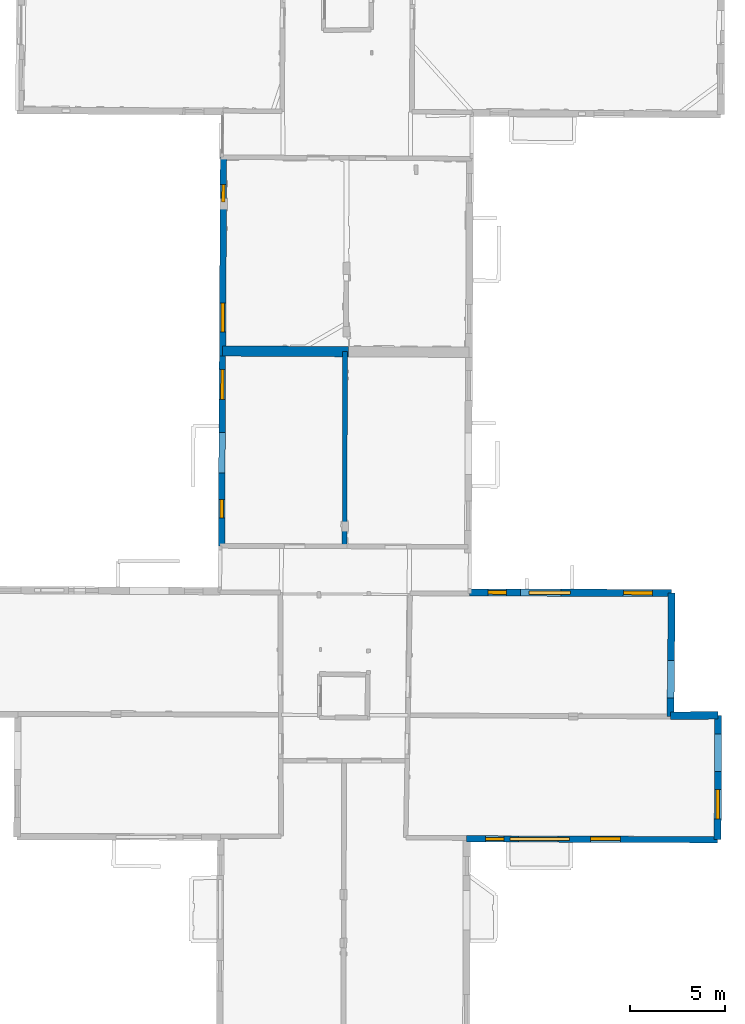
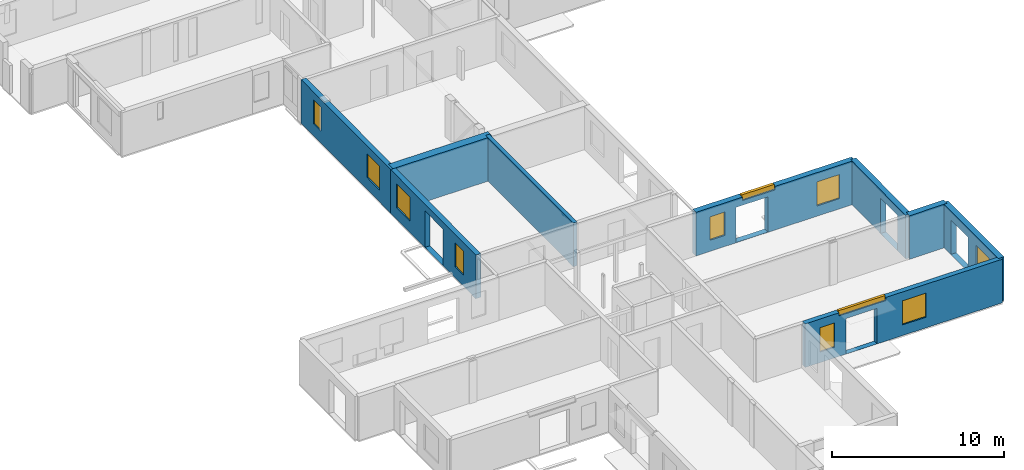
# One storey, part 7 of 17: 11 windows, 9 walls, 16 openings.
"""IFC2X3 building model written with IfcOpenShell, lengths in metres."""

from ifc_helpers import new_model, entity, si_unit, converted_unit, derived_unit, direction, frame, frame_2d, origin, origin_2d_with_axis, place, context, subcontext, project, spatial, polyline, rectangle, outline, extrude, clip, halfspace, source, transform, mapped, material, layer, layer_set, layer_usage, type_object, type_shapes, element, fill, save


model = new_model("IFC2X3")

# Units and contexts
model_context = context("Model", 3, precision=1e-05, world=origin(), true_north=direction((0.0, 1.0)))
body_context = subcontext(model_context, "Body", "Model", "MODEL_VIEW")
ifc_project = project(units=[si_unit("LENGTHUNIT", "METRE"), si_unit("AREAUNIT", "SQUARE_METRE"), si_unit("VOLUMEUNIT", "CUBIC_METRE"), converted_unit("PLANEANGLEUNIT", "DEGREE", entity("IfcRatioMeasure", 0.0174532925199433), si_unit("PLANEANGLEUNIT", "RADIAN"), dimensions=[0, 0, 0, 0, 0, 0, 0]), si_unit("MASSUNIT", "GRAM", prefix="KILO"), derived_unit("MASSDENSITYUNIT", [(si_unit("MASSUNIT", "GRAM", prefix="KILO"), 1), (si_unit("LENGTHUNIT", "METRE"), -3)]), derived_unit("MOMENTOFINERTIAUNIT", [(si_unit("LENGTHUNIT", "METRE"), 4)]), si_unit("TIMEUNIT", "SECOND"), si_unit("FREQUENCYUNIT", "HERTZ"), si_unit("THERMODYNAMICTEMPERATUREUNIT", "DEGREE_CELSIUS"), derived_unit("THERMALTRANSMITTANCEUNIT", [(si_unit("MASSUNIT", "GRAM", prefix="KILO"), 1), (si_unit("THERMODYNAMICTEMPERATUREUNIT", "KELVIN"), -1), (si_unit("TIMEUNIT", "SECOND"), -3)]), derived_unit("VOLUMETRICFLOWRATEUNIT", [(si_unit("LENGTHUNIT", "METRE"), 3), (si_unit("TIMEUNIT", "SECOND"), -1)]), si_unit("ELECTRICCURRENTUNIT", "AMPERE"), si_unit("ELECTRICVOLTAGEUNIT", "VOLT"), si_unit("POWERUNIT", "WATT"), si_unit("FORCEUNIT", "NEWTON", prefix="KILO"), si_unit("ILLUMINANCEUNIT", "LUX"), si_unit("LUMINOUSFLUXUNIT", "LUMEN"), si_unit("LUMINOUSINTENSITYUNIT", "CANDELA"), derived_unit("USERDEFINED", [(si_unit("MASSUNIT", "GRAM", prefix="KILO"), -1), (si_unit("LENGTHUNIT", "METRE"), -2), (si_unit("TIMEUNIT", "SECOND"), 3), (si_unit("LUMINOUSFLUXUNIT", "LUMEN"), 1)]), derived_unit("LINEARVELOCITYUNIT", [(si_unit("LENGTHUNIT", "METRE"), 1), (si_unit("TIMEUNIT", "SECOND"), -1)]), si_unit("PRESSUREUNIT", "PASCAL"), derived_unit("USERDEFINED", [(si_unit("LENGTHUNIT", "METRE"), -2), (si_unit("MASSUNIT", "GRAM", prefix="KILO"), 1), (si_unit("TIMEUNIT", "SECOND"), -2)]), derived_unit("LINEARFORCEUNIT", [(si_unit("MASSUNIT", "GRAM", prefix="KILO"), 1), (si_unit("LENGTHUNIT", "METRE"), 1), (si_unit("TIMEUNIT", "SECOND"), -2), (si_unit("LENGTHUNIT", "METRE"), -1)]), derived_unit("PLANARFORCEUNIT", [(si_unit("MASSUNIT", "GRAM", prefix="KILO"), 1), (si_unit("LENGTHUNIT", "METRE"), 1), (si_unit("TIMEUNIT", "SECOND"), -2), (si_unit("LENGTHUNIT", "METRE"), -2)])], contexts=[model_context])

# Site, building, storey
placement = place(None, origin())
site = spatial("IfcSite", under=ifc_project, at=placement, CompositionType="ELEMENT")
building = spatial("IfcBuilding", under=site, at=placement, CompositionType="ELEMENT")
storey_placement = place(placement, frame((0.0, 0.0, 12.0782108306885)))
storey = spatial("IfcBuildingStorey", under=building, at=storey_placement, Name="Level 5", CompositionType="ELEMENT", Elevation=12.0782108306885)

# Wall
ifc_material_1 = material(Name="Default wall")
ifc_layer_1 = layer(ifc_material_1, 0.25)
ifc_layer_set_1 = layer_set([ifc_layer_1], Name="wall_thickness_0.2500")
ifc_layer_usage_1 = layer_usage(ifc_layer_set_1, "AXIS2", "POSITIVE", -0.125)
wall_type_1 = type_object("IfcWallType", Name="wall_thickness_0.2500", PredefinedType="STANDARD", material=ifc_layer_set_1)
wall_1_placement = place(storey_placement, frame((6.2425833190648, 38.5537895721805, 0.0), z_axis=(0.0, 0.0, 1.0), x_axis=(-0.00288737001704187, -0.999995831538504, 0.0)))
element("IfcWallStandardCase", 1, at=wall_1_placement, inside=storey, type_object=wall_type_1, material=ifc_layer_usage_1, Name="Wall:287", ObjectType="Wall", context=body_context, shape_type="Clipping", body=[
    clip(extrude(outline(polyline([(10.2515934078109, -0.125), (10.2515934078109, 0.125), (0.0, 0.125), (0.0, -0.125), (10.2515934078109, -0.125)])), origin(), (0.0, 0.0, 1.0), 3.09134044647217), halfspace(frame((-37.2681875704859, -7.61302291375945, 5.79573318480268), z_axis=(-0.000288643336191914, -0.389900666933397, 0.920856876289642), x_axis=(0.00288817110946058, 0.920851484728657, 0.389902810378011)), False)),
])

# Wall, openings, windows
ifc_layer_2 = layer(ifc_material_1, 0.330000013113022)
ifc_layer_set_2 = layer_set([ifc_layer_2], Name="wall_thickness_0.3300")
ifc_layer_usage_2 = layer_usage(ifc_layer_set_2, "AXIS2", "POSITIVE", -0.165000006556511)
wall_type_2 = type_object("IfcWallType", Name="wall_thickness_0.3300", PredefinedType="STANDARD", material=ifc_layer_set_2)
wall_2_placement = place(storey_placement, frame((12.6459443218258, 12.9034908118024, 0.0), z_axis=(0.0, 0.0, 1.0), x_axis=(0.999992685574327, -0.00382476114882591, 0.0)))
wall_2 = element("IfcWallStandardCase", 2, at=wall_2_placement, inside=storey, type_object=wall_type_2, material=ifc_layer_usage_2, Name="Wall:361", ObjectType="Wall", context=body_context, shape_type="Clipping", body=[
    clip(extrude(outline(polyline([(13.21563468968, -0.165000006556511), (13.21563468968, 0.165000006556511), (0.0, 0.165000006556511), (0.0, -0.165000006556511), (13.21563468968, -0.165000006556511)])), origin(), (0.0, 0.0, 1.0), 3.09134044647217), halfspace(frame((-24.7044513587916, 6.59599809914678, 8.98689858314154), z_axis=(-0.00280531431875149, -0.389131394824783, 0.921177989192801), x_axis=(0.999981974712468, -0.0059817594498919, 0.000518463148508191)), False)),
])
opening_1_placement = place(wall_2_placement, frame((2.7329397110694, -0.165000006556511, 0.00578975677490234)))
element("IfcOpeningElement", 3, at=opening_1_placement, cuts=wall_2, Name="Opening : 2080 x 2520 : 295", ObjectType="Opening", context=body_context, shape_type="SweptSolid", body=[
    extrude(rectangle(XDim=2.08, YDim=2.52, at=frame_2d((1.26, 1.04), x_axis=(0.0, 1.0))), frame((0.0, 0.0, 0.0), z_axis=(0.0, 1.0, 0.0), x_axis=(0.0, 0.0, 1.0)), (0.0, 0.0, 1.0), 0.330000013113022),
])
opening_2_placement = place(wall_2_placement, frame((2.2772059384736, -0.165000006556511, 2.87078952789307)))
opening_2 = element("IfcOpeningElement", 4, at=opening_2_placement, cuts=wall_2, Name="Opening : 3125 x 310 : 296", ObjectType="Opening", context=body_context, shape_type="SweptSolid", body=[
    extrude(rectangle(XDim=3.125, YDim=0.31, at=frame_2d((0.155, 1.5625), x_axis=(0.0, 1.0))), frame((0.0, 0.0, 0.0), z_axis=(0.0, 1.0, 0.0), x_axis=(0.0, 0.0, 1.0)), (0.0, 0.0, 1.0), 0.330000013113022),
])
opening_3_placement = place(wall_2_placement, frame((6.52720650410301, -0.165000006556511, 0.755789756774902)))
opening_3 = element("IfcOpeningElement", 5, at=opening_3_placement, cuts=wall_2, Name="Opening : 1565 x 1710 : 297", ObjectType="Opening", context=body_context, shape_type="SweptSolid", body=[
    extrude(rectangle(XDim=1.565, YDim=1.71, at=frame_2d((0.855, 0.7825), x_axis=(0.0, 1.0))), frame((0.0, 0.0, 0.0), z_axis=(0.0, 1.0, 0.0), x_axis=(0.0, 0.0, 1.0)), (0.0, 0.0, 1.0), 0.330000013113022),
])
opening_4_placement = place(wall_2_placement, frame((0.987207030009488, -0.165000006556511, 0.755789756774902)))
opening_4 = element("IfcOpeningElement", 6, at=opening_4_placement, cuts=wall_2, Name="Opening : 980 x 1725 : 298", ObjectType="Opening", context=body_context, shape_type="SweptSolid", body=[
    extrude(rectangle(XDim=0.98, YDim=1.725, at=frame_2d((0.8625, 0.49), x_axis=(0.0, 1.0))), frame((0.0, 0.0, 0.0), z_axis=(0.0, 1.0, 0.0), x_axis=(0.0, 0.0, 1.0)), (0.0, 0.0, 1.0), 0.330000013113022),
])
ifc_material_2 = material(Name="Window Default")
window_style_1 = type_object("IfcWindowStyle", Name="Window : 1565 x 1710mm", ConstructionType="NOTDEFINED", OperationType="NOTDEFINED", ParameterTakesPrecedence=False, Sizeable=False, material=ifc_material_2)
shared_shape_1 = source(origin(), body_context, "Body", "SweptSolid", [
    extrude(rectangle(XDim=0.185000002384186, YDim=1.565, at=origin_2d_with_axis()), frame((0.7825, 0.185000002384186, 0.0), z_axis=(0.0, 0.0, 1.0), x_axis=(0.0, 1.0, 0.0)), (0.0, 0.0, 1.0), 1.71),
])
type_shapes(window_style_1, [shared_shape_1])
window_1_placement = place(opening_3_placement, origin())
window_1 = element("IfcWindow", 7, at=window_1_placement, inside=storey, type_object=window_style_1, Name="Window : 1565 x 1710mm : 163", ObjectType="Window : 1565 x 1710mm", OverallHeight=1.71, OverallWidth=1.565, context=body_context, shape_type="MappedRepresentation", body=[
    mapped(shared_shape_1, transform((0.0, 0.0, 0.0), scale=1.0)),
])
fill(opening_3, window_1)
window_style_2 = type_object("IfcWindowStyle", Name="Window : 3125 x 310mm", ConstructionType="NOTDEFINED", OperationType="NOTDEFINED", ParameterTakesPrecedence=False, Sizeable=False, material=ifc_material_2)
shared_shape_2 = source(origin(), body_context, "Body", "SweptSolid", [
    extrude(rectangle(XDim=0.165000006556511, YDim=3.125, at=origin_2d_with_axis()), frame((1.5625, 0.165000006556511, 0.0), z_axis=(0.0, 0.0, 1.0), x_axis=(0.0, 1.0, 0.0)), (0.0, 0.0, 1.0), 0.31),
])
type_shapes(window_style_2, [shared_shape_2])
window_2_placement = place(opening_2_placement, origin())
window_2 = element("IfcWindow", 8, at=window_2_placement, inside=storey, type_object=window_style_2, Name="Window : 3125 x 310mm : 162", ObjectType="Window : 3125 x 310mm", OverallHeight=0.31, OverallWidth=3.125, context=body_context, shape_type="MappedRepresentation", body=[
    mapped(shared_shape_2, transform((0.0, 0.0, 0.0), scale=1.0)),
])
fill(opening_2, window_2)
window_style_3 = type_object("IfcWindowStyle", Name="Window : 980 x 1725mm", ConstructionType="NOTDEFINED", OperationType="NOTDEFINED", ParameterTakesPrecedence=False, Sizeable=False, material=ifc_material_2)
shared_shape_3 = source(origin(), body_context, "Body", "SweptSolid", [
    extrude(rectangle(XDim=0.165000006556511, YDim=0.98, at=origin_2d_with_axis()), frame((0.49, 0.165000006556511, 0.0), z_axis=(0.0, 0.0, 1.0), x_axis=(0.0, 1.0, 0.0)), (0.0, 0.0, 1.0), 1.725),
])
type_shapes(window_style_3, [shared_shape_3])
window_3_placement = place(opening_4_placement, origin())
window_3 = element("IfcWindow", 9, at=window_3_placement, inside=storey, type_object=window_style_3, Name="Window : 980 x 1725mm : 164", ObjectType="Window : 980 x 1725mm", OverallHeight=1.725, OverallWidth=0.98, context=body_context, shape_type="MappedRepresentation", body=[
    mapped(shared_shape_3, transform((0.0, 0.0, 0.0), scale=1.0)),
])
fill(opening_4, window_3)

ifc_layer_3 = layer(ifc_material_1, 0.379999995231628)
ifc_layer_set_3 = layer_set([ifc_layer_3], Name="wall_thickness_0.3800")
ifc_layer_usage_3 = layer_usage(ifc_layer_set_3, "AXIS2", "POSITIVE", -0.189999997615814)
wall_type_3 = type_object("IfcWallType", Name="wall_thickness_0.3800", PredefinedType="STANDARD", material=ifc_layer_set_3)
wall_3_placement = place(storey_placement, frame((12.8049669561758, 25.8791082849404, 0.0), z_axis=(0.0, 0.0, 1.0), x_axis=(0.999993542555553, -0.00359372330525261, 0.0)))
wall_3 = element("IfcWallStandardCase", 10, at=wall_3_placement, inside=storey, type_object=wall_type_3, material=ifc_layer_usage_3, Name="Wall:334", ObjectType="Wall", context=body_context, shape_type="Clipping", body=[
    clip(extrude(outline(polyline([(10.6366491527951, -0.189999997615814), (10.6366491527951, 0.189999997615814), (0.0, 0.189999997615814), (0.0, -0.189999997615814), (10.6366491527951, -0.189999997615814)])), origin(), (0.0, 0.0, 1.0), 3.09134044647217), halfspace(frame((11.5985971692035, -6.60063518683249, 9.08176747891542), z_axis=(0.00194004725521499, 0.389131320326817, 0.921180249330909), x_axis=(-0.999980566389466, 0.00621273232471894, -0.000518459702406835)), False)),
])
opening_5_placement = place(wall_3_placement, frame((2.68217481923566, -0.189999997615814, 0.0177888870239258)))
element("IfcOpeningElement", 11, at=opening_5_placement, cuts=wall_3, Name="Opening : 2120 x 2495 : 280", ObjectType="Opening", context=body_context, shape_type="SweptSolid", body=[
    extrude(rectangle(XDim=2.12, YDim=2.495, at=frame_2d((1.2475, 1.06), x_axis=(0.0, 1.0))), frame((0.0, 0.0, 0.0), z_axis=(0.0, 1.0, 0.0), x_axis=(0.0, 0.0, 1.0)), (0.0, 0.0, 1.0), 0.379999995231628),
])
opening_6_placement = place(wall_3_placement, frame((8.08478329656642, -0.189999997615814, 0.725790023803711)))
opening_6 = element("IfcOpeningElement", 12, at=opening_6_placement, cuts=wall_3, Name="Opening : 1530 x 1710 : 281", ObjectType="Opening", context=body_context, shape_type="SweptSolid", body=[
    extrude(rectangle(XDim=1.53, YDim=1.71, at=frame_2d((0.855, 0.765), x_axis=(0.0, 1.0))), frame((0.0, 0.0, 0.0), z_axis=(0.0, 1.0, 0.0), x_axis=(0.0, 0.0, 1.0)), (0.0, 0.0, 1.0), 0.379999995231628),
])
opening_7_placement = place(wall_3_placement, frame((0.949781812283039, -0.189999997615814, 0.785789489746094)))
opening_7 = element("IfcOpeningElement", 13, at=opening_7_placement, cuts=wall_3, Name="Opening : 975 x 1665 : 282", ObjectType="Opening", context=body_context, shape_type="SweptSolid", body=[
    extrude(rectangle(XDim=0.975, YDim=1.665, at=frame_2d((0.8325, 0.4875), x_axis=(0.0, 1.0))), frame((0.0, 0.0, 0.0), z_axis=(0.0, 1.0, 0.0), x_axis=(0.0, 0.0, 1.0)), (0.0, 0.0, 1.0), 0.379999995231628),
])
opening_8_placement = place(wall_3_placement, frame((3.11860879774614, -0.189999997615814, 2.84578990936279)))
opening_8 = element("IfcOpeningElement", 14, at=opening_8_placement, cuts=wall_3, Name="Opening : 2175 x 335 : 283", ObjectType="Opening", context=body_context, shape_type="SweptSolid", body=[
    extrude(rectangle(XDim=2.175, YDim=0.335, at=frame_2d((0.1675, 1.0875), x_axis=(0.0, 1.0))), frame((0.0, 0.0, 0.0), z_axis=(0.0, 1.0, 0.0), x_axis=(0.0, 0.0, 1.0)), (0.0, 0.0, 1.0), 0.379999995231628),
])
window_style_4 = type_object("IfcWindowStyle", Name="Window : 1530 x 1710mm", ConstructionType="NOTDEFINED", OperationType="NOTDEFINED", ParameterTakesPrecedence=False, Sizeable=False, material=ifc_material_2)
shared_shape_4 = source(origin(), body_context, "Body", "SweptSolid", [
    extrude(rectangle(XDim=0.189999997615814, YDim=1.53, at=origin_2d_with_axis()), frame((0.765, 0.189999997615814, 0.0), z_axis=(0.0, 0.0, 1.0), x_axis=(0.0, 1.0, 0.0)), (0.0, 0.0, 1.0), 1.71),
])
type_shapes(window_style_4, [shared_shape_4])
window_4_placement = place(opening_6_placement, origin())
window_4 = element("IfcWindow", 15, at=window_4_placement, inside=storey, type_object=window_style_4, Name="Window : 1530 x 1710mm : 153", ObjectType="Window : 1530 x 1710mm", OverallHeight=1.71, OverallWidth=1.53, context=body_context, shape_type="MappedRepresentation", body=[
    mapped(shared_shape_4, transform((0.0, 0.0, 0.0), scale=1.0)),
])
fill(opening_6, window_4)
window_style_5 = type_object("IfcWindowStyle", Name="Window : 975 x 1665mm", ConstructionType="NOTDEFINED", OperationType="NOTDEFINED", ParameterTakesPrecedence=False, Sizeable=False, material=ifc_material_2)
shared_shape_5 = source(origin(), body_context, "Body", "SweptSolid", [
    extrude(rectangle(XDim=0.189999997615814, YDim=0.975, at=origin_2d_with_axis()), frame((0.4875, 0.189999997615814, 0.0), z_axis=(0.0, 0.0, 1.0), x_axis=(0.0, 1.0, 0.0)), (0.0, 0.0, 1.0), 1.665),
])
type_shapes(window_style_5, [shared_shape_5])
window_5_placement = place(opening_7_placement, origin())
window_5 = element("IfcWindow", 16, at=window_5_placement, inside=storey, type_object=window_style_5, Name="Window : 975 x 1665mm : 154", ObjectType="Window : 975 x 1665mm", OverallHeight=1.665, OverallWidth=0.975, context=body_context, shape_type="MappedRepresentation", body=[
    mapped(shared_shape_5, transform((0.0, 0.0, 0.0), scale=1.0)),
])
fill(opening_7, window_5)
window_style_6 = type_object("IfcWindowStyle", Name="Window : 2175 x 335mm", ConstructionType="NOTDEFINED", OperationType="NOTDEFINED", ParameterTakesPrecedence=False, Sizeable=False, material=ifc_material_2)
shared_shape_6 = source(origin(), body_context, "Body", "SweptSolid", [
    extrude(rectangle(XDim=0.189999997615814, YDim=2.175, at=origin_2d_with_axis()), frame((1.0875, 0.189999997615814, 0.0), z_axis=(0.0, 0.0, 1.0), x_axis=(0.0, 1.0, 0.0)), (0.0, 0.0, 1.0), 0.335),
])
type_shapes(window_style_6, [shared_shape_6])
window_6_placement = place(opening_8_placement, origin())
window_6 = element("IfcWindow", 17, at=window_6_placement, inside=storey, type_object=window_style_6, Name="Window : 2175 x 335mm : 155", ObjectType="Window : 2175 x 335mm", OverallHeight=0.335, OverallWidth=2.175, context=body_context, shape_type="MappedRepresentation", body=[
    mapped(shared_shape_6, transform((0.0, 0.0, 0.0), scale=1.0)),
])
fill(opening_8, window_6)

ifc_layer_4 = layer(ifc_material_1, 0.340000003576279)
ifc_layer_set_4 = layer_set([ifc_layer_4], Name="wall_thickness_0.3400")
ifc_layer_usage_4 = layer_usage(ifc_layer_set_4, "AXIS2", "POSITIVE", -0.170000001788139)
wall_type_4 = type_object("IfcWallType", Name="wall_thickness_0.3400", PredefinedType="STANDARD", material=ifc_layer_set_4)
wall_4_placement = place(storey_placement, frame((-0.15967737874855, 48.7973788329613, 0.0), z_axis=(0.0, 0.0, 1.0), x_axis=(-0.00520422343838304, -0.999986457937508, 0.0)))
wall_4 = element("IfcWallStandardCase", 18, at=wall_4_placement, inside=storey, type_object=wall_type_4, material=ifc_layer_usage_4, Name="Wall:337", ObjectType="Wall", context=body_context, shape_type="Clipping", body=[
    clip(extrude(outline(polyline([(10.4791839629867, -0.170000001788139), (10.4791839629867, 0.170000001788139), (0.0, 0.170000001788139), (0.0, -0.170000001788139), (10.4791839629867, -0.170000001788139)])), origin(), (0.0, 0.0, 1.0), 3.09134044647217), halfspace(frame((-27.0403174075982, -1.24386413209245, 5.79573318480268), z_axis=(0.000614706919813395, -0.389900289209288, 0.920856876289642), x_axis=(0.000754669415241038, 0.920855704729793, 0.389902810378011)), False)),
])
opening_9_placement = place(wall_4_placement, frame((7.68971366325704, -0.170000001788139, 0.845789909362793)))
opening_9 = element("IfcOpeningElement", 19, at=opening_9_placement, cuts=wall_4, Name="Opening : 1520 x 1675 : 284", ObjectType="Opening", context=body_context, shape_type="SweptSolid", body=[
    extrude(rectangle(XDim=1.52, YDim=1.675, at=frame_2d((0.8375, 0.76), x_axis=(0.0, 1.0))), frame((0.0, 0.0, 0.0), z_axis=(0.0, 1.0, 0.0), x_axis=(0.0, 0.0, 1.0)), (0.0, 0.0, 1.0), 0.340000003576279),
])
opening_10_placement = place(wall_4_placement, frame((1.42970686245111, -0.170000001788139, 0.840789794921875)))
opening_10 = element("IfcOpeningElement", 20, at=opening_10_placement, cuts=wall_4, Name="Opening : 925 x 1695 : 285", ObjectType="Opening", context=body_context, shape_type="SweptSolid", body=[
    extrude(rectangle(XDim=0.925, YDim=1.695, at=frame_2d((0.8475, 0.4625), x_axis=(0.0, 1.0))), frame((0.0, 0.0, 0.0), z_axis=(0.0, 1.0, 0.0), x_axis=(0.0, 0.0, 1.0)), (0.0, 0.0, 1.0), 0.340000003576279),
])
window_style_7 = type_object("IfcWindowStyle", Name="Window : 1520 x 1675mm", ConstructionType="NOTDEFINED", OperationType="NOTDEFINED", ParameterTakesPrecedence=False, Sizeable=False, material=ifc_material_2)
shared_shape_7 = source(origin(), body_context, "Body", "SweptSolid", [
    extrude(rectangle(XDim=0.170000001788139, YDim=1.52, at=origin_2d_with_axis()), frame((0.76, 0.170000001788139, 0.0), z_axis=(0.0, 0.0, 1.0), x_axis=(0.0, 1.0, 0.0)), (0.0, 0.0, 1.0), 1.675),
])
type_shapes(window_style_7, [shared_shape_7])
window_7_placement = place(opening_9_placement, origin())
window_7 = element("IfcWindow", 21, at=window_7_placement, inside=storey, type_object=window_style_7, Name="Window : 1520 x 1675mm : 156", ObjectType="Window : 1520 x 1675mm", OverallHeight=1.675, OverallWidth=1.52, context=body_context, shape_type="MappedRepresentation", body=[
    mapped(shared_shape_7, transform((0.0, 0.0, 0.0), scale=1.0)),
])
fill(opening_9, window_7)
window_style_8 = type_object("IfcWindowStyle", Name="Window : 925 x 1695mm", ConstructionType="NOTDEFINED", OperationType="NOTDEFINED", ParameterTakesPrecedence=False, Sizeable=False, material=ifc_material_2)
shared_shape_8 = source(origin(), body_context, "Body", "SweptSolid", [
    extrude(rectangle(XDim=0.170000001788139, YDim=0.925, at=origin_2d_with_axis()), frame((0.4625, 0.170000001788139, 0.0), z_axis=(0.0, 0.0, 1.0), x_axis=(0.0, 1.0, 0.0)), (0.0, 0.0, 1.0), 1.695),
])
type_shapes(window_style_8, [shared_shape_8])
window_8_placement = place(opening_10_placement, origin())
window_8 = element("IfcWindow", 22, at=window_8_placement, inside=storey, type_object=window_style_8, Name="Window : 925 x 1695mm : 157", ObjectType="Window : 925 x 1695mm", OverallHeight=1.695, OverallWidth=0.925, context=body_context, shape_type="MappedRepresentation", body=[
    mapped(shared_shape_8, transform((0.0, 0.0, 0.0), scale=1.0)),
])
fill(opening_10, window_8)

wall_5_placement = place(storey_placement, frame((-0.214213393543854, 38.3183367797386, 0.0), z_axis=(0.0, 0.0, 1.0), x_axis=(-0.0052042204768318, -0.999986457952921, 0.0)))
wall_5 = element("IfcWallStandardCase", 23, at=wall_5_placement, inside=storey, type_object=wall_type_4, material=ifc_layer_usage_4, Name="Wall:338", ObjectType="Wall", context=body_context, shape_type="Clipping", body=[
    clip(extrude(outline(polyline([(9.9898317854579, -0.170000001788139), (9.9898317854579, 0.170000001788139), (0.0, 0.170000001788139), (0.0, -0.170000001788139), (9.9898317854579, -0.170000001788139)])), origin(), (0.0, 0.0, 1.0), 3.09134044647217), halfspace(frame((-37.5195013742688, -1.24386402097502, 5.79573318480268), z_axis=(0.000614705765088045, -0.389900289211108, 0.920856876289642), x_axis=(0.000754672142438538, 0.920855704727558, 0.389902810378011)), False)),
])
opening_11_placement = place(wall_5_placement, frame((4.02999994841722, -0.170000001788139, 0.0177888870239258)))
element("IfcOpeningElement", 24, at=opening_11_placement, cuts=wall_5, Name="Opening : 2135 x 2590 : 286", ObjectType="Opening", context=body_context, shape_type="SweptSolid", body=[
    extrude(rectangle(XDim=2.135, YDim=2.59, at=frame_2d((1.295, 1.0675), x_axis=(0.0, 1.0))), frame((0.0, 0.0, 0.0), z_axis=(0.0, 1.0, 0.0), x_axis=(0.0, 0.0, 1.0)), (0.0, 0.0, 1.0), 0.340000003576279),
])
opening_12_placement = place(wall_5_placement, frame((0.690526777174293, -0.170000001788139, 0.810790061950684)))
opening_12 = element("IfcOpeningElement", 25, at=opening_12_placement, cuts=wall_5, Name="Opening : 1595 x 1695 : 287", ObjectType="Opening", context=body_context, shape_type="SweptSolid", body=[
    extrude(rectangle(XDim=1.595, YDim=1.695, at=frame_2d((0.8475, 0.7975), x_axis=(0.0, 1.0))), frame((0.0, 0.0, 0.0), z_axis=(0.0, 1.0, 0.0), x_axis=(0.0, 0.0, 1.0)), (0.0, 0.0, 1.0), 0.340000003576279),
])
opening_13_placement = place(wall_5_placement, frame((7.54552759754386, -0.170000001788139, 0.79578971862793)))
opening_13 = element("IfcOpeningElement", 26, at=opening_13_placement, cuts=wall_5, Name="Opening : 975 x 1685 : 288", ObjectType="Opening", context=body_context, shape_type="SweptSolid", body=[
    extrude(rectangle(XDim=0.975, YDim=1.685, at=frame_2d((0.8425, 0.4875), x_axis=(0.0, 1.0))), frame((0.0, 0.0, 0.0), z_axis=(0.0, 1.0, 0.0), x_axis=(0.0, 0.0, 1.0)), (0.0, 0.0, 1.0), 0.340000003576279),
])
window_style_9 = type_object("IfcWindowStyle", Name="Window : 1595 x 1695mm", ConstructionType="NOTDEFINED", OperationType="NOTDEFINED", ParameterTakesPrecedence=False, Sizeable=False, material=ifc_material_2)
shared_shape_9 = source(origin(), body_context, "Body", "SweptSolid", [
    extrude(rectangle(XDim=0.170000001788139, YDim=1.595, at=origin_2d_with_axis()), frame((0.7975, 0.170000001788139, 0.0), z_axis=(0.0, 0.0, 1.0), x_axis=(0.0, 1.0, 0.0)), (0.0, 0.0, 1.0), 1.695),
])
type_shapes(window_style_9, [shared_shape_9])
window_9_placement = place(opening_12_placement, origin())
window_9 = element("IfcWindow", 27, at=window_9_placement, inside=storey, type_object=window_style_9, Name="Window : 1595 x 1695mm : 158", ObjectType="Window : 1595 x 1695mm", OverallHeight=1.695, OverallWidth=1.595, context=body_context, shape_type="MappedRepresentation", body=[
    mapped(shared_shape_9, transform((0.0, 0.0, 0.0), scale=1.0)),
])
fill(opening_12, window_9)
window_style_10 = type_object("IfcWindowStyle", Name="Window : 975 x 1685mm", ConstructionType="NOTDEFINED", OperationType="NOTDEFINED", ParameterTakesPrecedence=False, Sizeable=False, material=ifc_material_2)
shared_shape_10 = source(origin(), body_context, "Body", "SweptSolid", [
    extrude(rectangle(XDim=0.170000001788139, YDim=0.975, at=origin_2d_with_axis()), frame((0.4875, 0.170000001788139, 0.0), z_axis=(0.0, 0.0, 1.0), x_axis=(0.0, 1.0, 0.0)), (0.0, 0.0, 1.0), 1.685),
])
type_shapes(window_style_10, [shared_shape_10])
window_10_placement = place(opening_13_placement, origin())
window_10 = element("IfcWindow", 28, at=window_10_placement, inside=storey, type_object=window_style_10, Name="Window : 975 x 1685mm : 159", ObjectType="Window : 975 x 1685mm", OverallHeight=1.685, OverallWidth=0.975, context=body_context, shape_type="MappedRepresentation", body=[
    mapped(shared_shape_10, transform((0.0, 0.0, 0.0), scale=1.0)),
])
fill(opening_13, window_10)

# Wall, opening
ifc_layer_5 = layer(ifc_material_1, 0.370000004768372)
ifc_layer_set_5 = layer_set([ifc_layer_5], Name="wall_thickness_0.3700")
ifc_layer_usage_5 = layer_usage(ifc_layer_set_5, "AXIS2", "POSITIVE", -0.185000002384186)
wall_type_5 = type_object("IfcWallType", Name="wall_thickness_0.3700", PredefinedType="STANDARD", material=ifc_layer_set_5)
wall_6_placement = place(storey_placement, frame((23.441548245079, 25.8408882780081, 0.0), z_axis=(0.0, 0.0, 1.0), x_axis=(-0.00987290866871752, -0.999951261649496, 0.0)))
wall_6 = element("IfcWallStandardCase", 29, at=wall_6_placement, inside=storey, type_object=wall_type_5, material=ifc_layer_usage_5, Name="Wall:304", ObjectType="Wall", context=body_context, shape_type="Clipping", body=[
    clip(extrude(outline(polyline([(6.50451890856051, -0.185000002384186), (6.50451890856051, 0.185000002384186), (0.0, 0.185000002384186), (0.0, -0.185000002384186), (6.50451890856051, -0.185000002384186)])), origin(), (0.0, 0.0, 1.0), 3.09134044647217), halfspace(frame((6.5944698732673, 1.00337562815348, 9.08176747891542), z_axis=(-0.389135830743747, -0.000503462032437757, 0.921180249330909), x_axis=(6.65648916078435e-05, -0.999999863384317, -0.000518459702406835)), False)),
])
opening_14_placement = place(wall_6_placement, frame((3.54651194608771, -0.185000002384186, 0.00578975677490234)))
element("IfcOpeningElement", 30, at=opening_14_placement, cuts=wall_6, Name="Opening : 1980 x 2500 : 253", ObjectType="Opening", context=body_context, shape_type="SweptSolid", body=[
    extrude(rectangle(XDim=1.98, YDim=2.5, at=frame_2d((1.25, 0.99), x_axis=(0.0, 1.0))), frame((0.0, 0.0, 0.0), z_axis=(0.0, 1.0, 0.0), x_axis=(0.0, 0.0, 1.0)), (0.0, 0.0, 1.0), 0.370000004768372),
])

# Wall, openings, window
wall_7_placement = place(storey_placement, frame((25.8847014024344, 19.3998833272423, 0.0), z_axis=(0.0, 0.0, 1.0), x_axis=(-0.00354697474297455, -0.999993709465301, 0.0)))
wall_7 = element("IfcWallStandardCase", 31, at=wall_7_placement, inside=storey, type_object=wall_type_5, material=ifc_layer_usage_5, Name="Wall:340", ObjectType="Wall", context=body_context, shape_type="SweptSolid", body=[
    extrude(outline(polyline([(6.54697912650425, -0.185000002384186), (6.54697912650425, 0.185000002384186), (0.0, 0.185000002384186), (0.0, -0.185000002384186), (6.54697912650425, -0.185000002384186)])), origin(), (0.0, 0.0, 1.0), 3.09134044647217),
])
opening_15_placement = place(wall_7_placement, frame((0.987703810632803, -0.185000002384186, 0.00578975677490234)))
element("IfcOpeningElement", 32, at=opening_15_placement, cuts=wall_7, Name="Opening : 1975 x 2445 : 290", ObjectType="Opening", context=body_context, shape_type="SweptSolid", body=[
    extrude(rectangle(XDim=1.975, YDim=2.445, at=frame_2d((1.2225, 0.9875), x_axis=(0.0, 1.0))), frame((0.0, 0.0, 0.0), z_axis=(0.0, 1.0, 0.0), x_axis=(0.0, 0.0, 1.0)), (0.0, 0.0, 1.0), 0.370000004768372),
])
opening_16_placement = place(wall_7_placement, frame((3.91270427841593, -0.185000002384186, 0.755789756774902)))
opening_16 = element("IfcOpeningElement", 33, at=opening_16_placement, cuts=wall_7, Name="Opening : 1555 x 1695 : 291", ObjectType="Opening", context=body_context, shape_type="SweptSolid", body=[
    extrude(rectangle(XDim=1.555, YDim=1.695, at=frame_2d((0.8475, 0.7775), x_axis=(0.0, 1.0))), frame((0.0, 0.0, 0.0), z_axis=(0.0, 1.0, 0.0), x_axis=(0.0, 0.0, 1.0)), (0.0, 0.0, 1.0), 0.370000004768372),
])
window_style_11 = type_object("IfcWindowStyle", Name="Window : 1555 x 1695mm", ConstructionType="NOTDEFINED", OperationType="NOTDEFINED", ParameterTakesPrecedence=False, Sizeable=False, material=ifc_material_2)
shared_shape_11 = source(origin(), body_context, "Body", "SweptSolid", [
    extrude(rectangle(XDim=0.185000002384186, YDim=1.555, at=origin_2d_with_axis()), frame((0.7775, 0.185000002384186, 0.0), z_axis=(0.0, 0.0, 1.0), x_axis=(0.0, 1.0, 0.0)), (0.0, 0.0, 1.0), 1.695),
])
type_shapes(window_style_11, [shared_shape_11])
window_11_placement = place(opening_16_placement, origin())
window_11 = element("IfcWindow", 34, at=window_11_placement, inside=storey, type_object=window_style_11, Name="Window : 1555 x 1695mm : 160", ObjectType="Window : 1555 x 1695mm", OverallHeight=1.695, OverallWidth=1.555, context=body_context, shape_type="MappedRepresentation", body=[
    mapped(shared_shape_11, transform((0.0, 0.0, 0.0), scale=1.0)),
])
fill(opening_16, window_11)

# Walls
ifc_layer_6 = layer(ifc_material_1, 0.540000021457672)
ifc_layer_set_6 = layer_set([ifc_layer_6], Name="wall_thickness_0.5400")
ifc_layer_usage_6 = layer_usage(ifc_layer_set_6, "AXIS2", "POSITIVE", -0.270000010728836)
wall_type_6 = type_object("IfcWallType", Name="wall_thickness_0.5400", PredefinedType="STANDARD", material=ifc_layer_set_6)
wall_8_placement = place(storey_placement, frame((-0.212808031370733, 38.5883326312469, 0.0), z_axis=(0.0, 0.0, 1.0), x_axis=(0.999985681521006, -0.00535133188732531, 0.0)))
element("IfcWallStandardCase", 35, at=wall_8_placement, inside=storey, type_object=wall_type_6, material=ifc_layer_usage_6, Name="Wall:264", ObjectType="Wall", context=body_context, shape_type="Clipping", body=[
    clip(extrude(outline(polyline([(6.62736702287434, -0.270000010728836), (6.62736702287434, 0.270000010728836), (0.0, 0.270000010728836), (0.0, -0.270000010728836), (6.62736702287434, -0.270000010728836)])), origin(), (0.0, 0.0, 1.0), 3.09134044647217), halfspace(frame((-1.24934413578391, 37.2493184729869, 5.79573318480268), z_axis=(-0.389900194560434, -0.000672065338657588, 0.920856876289642), x_axis=(0.920855805785237, -0.000619201866286294, 0.389902810378011)), False)),
])
ifc_layer_7 = layer(ifc_material_1, 0.400000005960464)
ifc_layer_set_7 = layer_set([ifc_layer_7], Name="wall_thickness_0.4000")
ifc_layer_usage_7 = layer_usage(ifc_layer_set_7, "AXIS2", "POSITIVE", -0.200000002980232)
wall_type_7 = type_object("IfcWallType", Name="wall_thickness_0.4000", PredefinedType="STANDARD", material=ifc_layer_set_7)
wall_9_placement = place(storey_placement, frame((23.3778232809293, 19.3865869019492, 0.0), z_axis=(0.0, 0.0, 1.0), x_axis=(0.999985930757374, 0.00530455345047371, 0.0)))
element("IfcWallStandardCase", 36, at=wall_9_placement, inside=storey, type_object=wall_type_7, material=ifc_layer_usage_7, Name="Wall:284", ObjectType="Wall", context=body_context, shape_type="SweptSolid", body=[
    extrude(outline(polyline([(2.50690935478861, -0.200000002980232), (2.50690935478861, 0.200000002980232), (0.0, 0.200000002980232), (0.0, -0.200000002980232), (2.50690935478861, -0.200000002980232)])), origin(), (0.0, 0.0, 1.0), 3.09134044647217),
])

save(model, "model.ifc")
